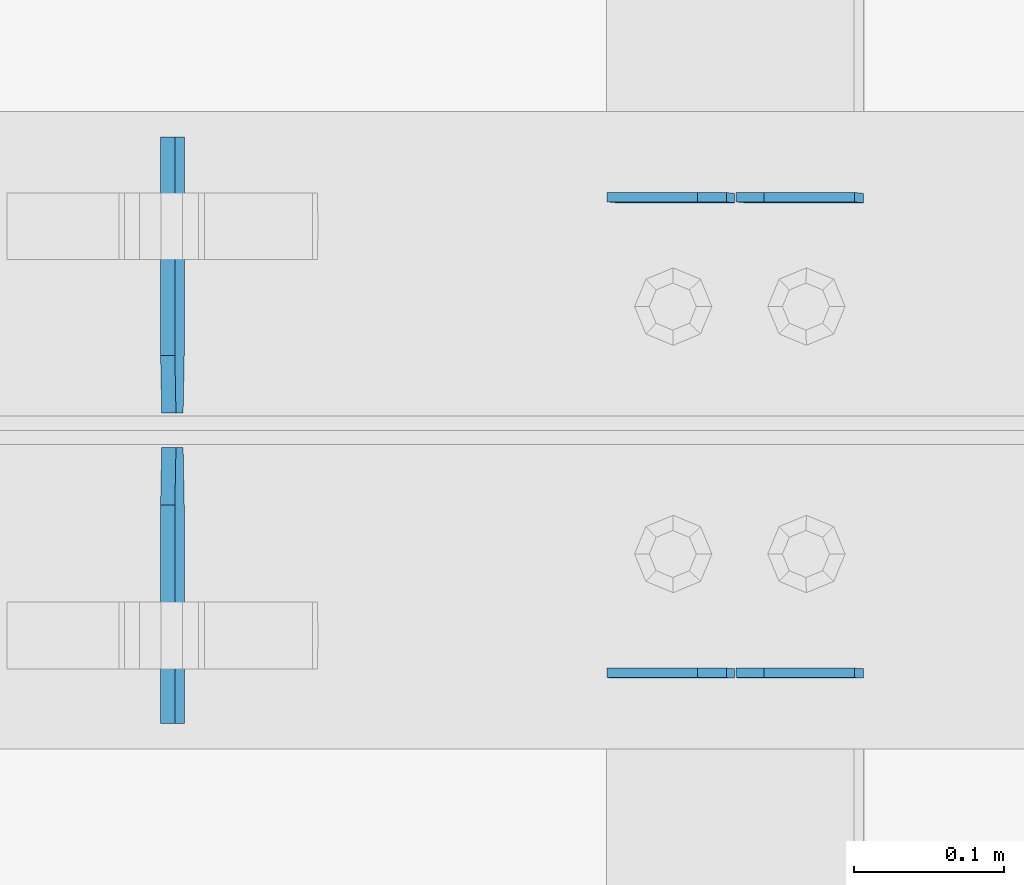
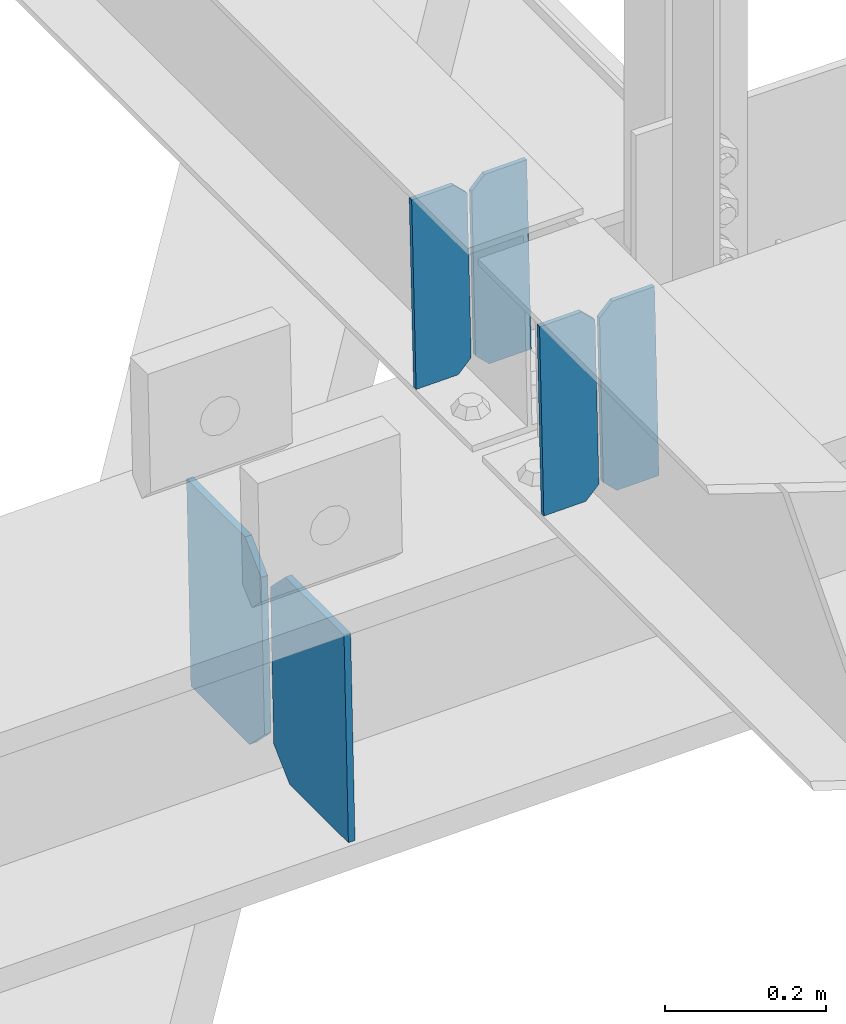
# One storey, part 3444 of 3843: 6 plates, 3 elements without a shape of their own.
"""IFC2X3 building model written with IfcOpenShell, lengths in millimetres."""

from ifc_helpers import new_model, si_unit, frame, origin_with_axes, place, context, subcontext, project, spatial, faceted_brep, material, type_object, element, aggregate, save


model = new_model("IFC2X3")

# Units and contexts
model_context = context("Model", 3, precision=1e-05, world=origin_with_axes())
body_context = subcontext(model_context, "Body", "Model", "MODEL_VIEW")
ifc_project = project(units=[si_unit("LENGTHUNIT", "METRE", prefix="MILLI"), si_unit("AREAUNIT", "SQUARE_METRE"), si_unit("VOLUMEUNIT", "CUBIC_METRE"), si_unit("MASSUNIT", "GRAM", prefix="KILO"), si_unit("TIMEUNIT", "SECOND"), si_unit("PLANEANGLEUNIT", "RADIAN"), si_unit("SOLIDANGLEUNIT", "STERADIAN"), si_unit("THERMODYNAMICTEMPERATUREUNIT", "DEGREE_CELSIUS"), si_unit("LUMINOUSINTENSITYUNIT", "LUMEN")], contexts=[model_context])

# Site, building, storey
site_placement = place(None, origin_with_axes())
site = spatial("IfcSite", under=ifc_project, at=site_placement, CompositionType="ELEMENT")
building_placement = place(site_placement, origin_with_axes())
building = spatial("IfcBuilding", under=site, at=building_placement, Name="Undefined", CompositionType="ELEMENT")
storey_placement = place(building_placement, origin_with_axes())
storey = spatial("IfcBuildingStorey", under=building, at=storey_placement, Name="Undefined", CompositionType="ELEMENT", Elevation=0.0)

# Assembly, plates
assembly_1_placement = place(storey_placement, origin_with_axes())
assembly_1 = element("IfcElementAssembly", 1, at=assembly_1_placement, inside=storey, Name="BEAM", AssemblyPlace="NOTDEFINED", PredefinedType="RIGID_FRAME")
ifc_material = material(Name="STEEL/A572-50")
plate_type_1 = type_object("IfcPlateType", PredefinedType="NOTDEFINED")
plate_1_placement = place(assembly_1_placement, frame((72027.796658837, 67426.8396238635, 46276.0659717988), z_axis=(-0.0211520979537891, 0.00212767700070982, 0.999774005334573), x_axis=(-0.999776269356297, -4.57939999836346e-05, -0.021152048007558)))
plate_1 = element("IfcPlate", 2, at=plate_1_placement, type_object=plate_type_1, material=ifc_material, Name="PLATE", context=body_context, shape_type="Brep", body=[
    faceted_brep([(0.0, -3.17499999999927, 0.0), (6.83940015733242e-10, -3.17499999996653, 288.924999998613), (6.54836185276508e-10, 3.17500000001746, 288.924999998591), (0.0, 3.17499999999927, 0.0), (60.3250007643655, -3.17500000017753, 288.924999998606), (60.3250007643219, 3.17499999979918, 288.924999998584), (79.3750000013097, -3.17500000025029, 269.875000761494), (79.375000001266, 3.17499999972642, 269.875000761487), (79.375000000713, -3.17500000026484, 19.0499992370605), (79.3750000006985, 3.17499999971187, 19.0499992370533), (60.325000763667, -3.17500000020664, -1.45519152283669e-11), (60.3250007636234, 3.17499999977736, -3.63797880709171e-11)], [[[0, 1, 2, 3]], [[1, 4, 5, 2]], [[4, 6, 7, 5]], [[6, 8, 9, 7]], [[8, 10, 11, 9]], [[10, 0, 3, 11]], [[5, 7, 9, 11, 3, 2]], [[10, 8, 6, 4, 1, 0]]]),
])
plate_2_placement = place(assembly_1_placement, frame((71942.0908381468, 67426.8357630742, 46274.2527123076), z_axis=(-0.0211520979537891, 0.00212767700070982, 0.999774005334573), x_axis=(-0.999776269356297, -4.57939999836346e-05, -0.021152048007558)))
plate_2 = element("IfcPlate", 3, at=plate_2_placement, type_object=plate_type_1, material=ifc_material, Name="PLATE", context=body_context, shape_type="Brep", body=[
    faceted_brep([(4.36557456851006e-11, -3.17499999998836, 19.0499992370969), (6.11180439591408e-10, -3.17499999996653, 269.875000761516), (5.96628524363041e-10, 3.17500000001746, 269.875000761502), (1.45519152283669e-11, 3.17499999998836, 19.0499992370824), (19.0499992376572, -3.17500000003201, 288.924999998606), (19.0499992376281, 3.1749999999447, 288.924999998584), (79.3750000013242, -3.17500000025029, 288.924999998591), (79.3750000013097, 3.1749999997337, 288.92499999857), (79.3750000006548, -3.17500000026484, -2.18278728425503e-11), (79.3750000006403, 3.17499999969732, -2.91038304567337e-11), (19.0499992370023, -3.17500000005384, 0.0), (19.0499992369587, 3.17499999992287, -1.45519152283669e-11)], [[[0, 1, 2, 3]], [[1, 4, 5, 2]], [[4, 6, 7, 5]], [[6, 8, 9, 7]], [[8, 10, 11, 9]], [[10, 0, 3, 11]], [[5, 7, 9, 11, 3, 2]], [[10, 8, 6, 4, 1, 0]]]),
])
aggregate(assembly_1, [plate_1, plate_2])

assembly_2_placement = place(storey_placement, origin_with_axes())
assembly_2 = element("IfcElementAssembly", 4, at=assembly_2_placement, inside=storey, Name="BEAM", AssemblyPlace="NOTDEFINED", PredefinedType="RIGID_FRAME")
plate_3_placement = place(assembly_2_placement, frame((72027.7966585924, 67109.8249895902, 46276.4772276004), z_axis=(-0.0211520976735046, 0.000503028999904926, 0.999776142806896), x_axis=(-0.999776269357269, -1.03370000525781e-05, -0.0211520950075214)))
plate_3 = element("IfcPlate", 5, at=plate_3_placement, type_object=plate_type_1, material=ifc_material, Name="PLATE", context=body_context, shape_type="Brep", body=[
    faceted_brep([(0.0, -3.17499999999927, 0.0), (6.83940015733242e-10, -3.17499999996653, 288.924999998613), (6.54836185276508e-10, 3.17500000001746, 288.924999998591), (0.0, 3.17499999999927, 0.0), (60.3250007643655, -3.17500000017753, 288.924999998606), (60.3250007643219, 3.17499999979918, 288.924999998584), (79.3750000013097, -3.17500000025029, 269.875000761494), (79.375000001266, 3.17499999972642, 269.875000761487), (79.375000000713, -3.17500000026484, 19.0499992370605), (79.3750000006985, 3.17499999971187, 19.0499992370533), (60.325000763667, -3.17500000020664, -1.45519152283669e-11), (60.3250007636234, 3.17499999977736, -3.63797880709171e-11)], [[[0, 1, 2, 3]], [[1, 4, 5, 2]], [[4, 6, 7, 5]], [[6, 8, 9, 7]], [[8, 10, 11, 9]], [[10, 0, 3, 11]], [[5, 7, 9, 11, 3, 2]], [[10, 8, 6, 4, 1, 0]]]),
])
plate_4_placement = place(assembly_2_placement, frame((71942.0908379013, 67109.8240791477, 46274.6639642276), z_axis=(-0.0211520976735046, 0.000503028999904926, 0.999776142806896), x_axis=(-0.999776269357269, -1.03370000525781e-05, -0.0211520950075214)))
plate_4 = element("IfcPlate", 6, at=plate_4_placement, type_object=plate_type_1, material=ifc_material, Name="PLATE", context=body_context, shape_type="Brep", body=[
    faceted_brep([(4.36557456851006e-11, -3.17499999998836, 19.0499992370969), (6.11180439591408e-10, -3.17499999996653, 269.875000761516), (5.96628524363041e-10, 3.17500000001746, 269.875000761502), (1.45519152283669e-11, 3.17499999998836, 19.0499992370824), (19.0499992376572, -3.17500000003201, 288.924999998606), (19.0499992376281, 3.1749999999447, 288.924999998584), (79.3750000013242, -3.17500000025029, 288.924999998591), (79.3750000013097, 3.1749999997337, 288.92499999857), (79.3750000006548, -3.17500000026484, -2.18278728425503e-11), (79.3750000006403, 3.17499999969732, -2.91038304567337e-11), (19.0499992370023, -3.17500000005384, 0.0), (19.0499992369587, 3.17499999992287, -1.45519152283669e-11)], [[[0, 1, 2, 3]], [[1, 4, 5, 2]], [[4, 6, 7, 5]], [[6, 8, 9, 7]], [[8, 10, 11, 9]], [[10, 0, 3, 11]], [[5, 7, 9, 11, 3, 2]], [[10, 8, 6, 4, 1, 0]]]),
])
aggregate(assembly_2, [plate_3, plate_4])

assembly_3_placement = place(storey_placement, origin_with_axes())
assembly_3 = element("IfcElementAssembly", 7, at=assembly_3_placement, inside=storey, Name="BEAM", AssemblyPlace="NOTDEFINED", PredefinedType="RIGID_FRAME")
plate_type_2 = type_object("IfcPlateType", PredefinedType="NOTDEFINED")
plate_5_placement = place(assembly_3_placement, frame((71569.8259376328, 67076.3375, 45900.4440101308), z_axis=(-0.019828109994094, 0.0, 0.999803403701979), x_axis=(0.0, 1.0, 0.0)))
plate_5 = element("IfcPlate", 8, at=plate_5_placement, type_object=plate_type_2, material=ifc_material, Name="PL", context=body_context, shape_type="Brep", body=[
    faceted_brep([(0.0, -4.76249999999709, 0.0), (0.0, -4.76249999986612, 316.893560966142), (0.0, 4.7625000000844, 316.893560966142), (0.0, 4.76249999999709, 0.0), (145.746763610834, -4.76249999986612, 316.893560966142), (145.746763610834, 4.7625000000844, 316.893560966142), (184.149999999994, -4.76249999989523, 278.490324577106), (184.149999999994, 4.76250000006985, 278.490324577098), (184.149999999994, -4.76249999999709, 38.4032363890365), (184.149999999994, 4.76249999998254, 38.4032363890365), (145.746763610834, -4.76250000001164, 7.27595761418343e-12), (145.746763610834, 4.76249999995343, 0.0)], [[[0, 1, 2, 3]], [[1, 4, 5, 2]], [[4, 6, 7, 5]], [[6, 8, 9, 7]], [[8, 10, 11, 9]], [[10, 0, 3, 11]], [[5, 7, 9, 11, 3, 2]], [[10, 8, 6, 4, 1, 0]]]),
])
plate_6_placement = place(assembly_3_placement, frame((71569.8259376328, 67283.3125, 45900.4440101308), z_axis=(-0.019828109994094, 0.0, 0.999803403701979), x_axis=(0.0, 1.0, 0.0)))
plate_6 = element("IfcPlate", 9, at=plate_6_placement, type_object=plate_type_2, material=ifc_material, Name="PL", context=body_context, shape_type="Brep", body=[
    faceted_brep([(0.0, -4.76249999999709, 38.4032363890365), (0.0, -4.76249999989523, 278.490324577106), (0.0, 4.76250000006985, 278.490324577098), (0.0, 4.76249999998254, 38.4032363890365), (38.4032363891602, -4.76249999986612, 316.893560966142), (38.4032363891602, 4.7625000000844, 316.893560966142), (184.149999999994, -4.76249999986612, 316.893560966142), (184.149999999994, 4.7625000000844, 316.893560966142), (184.150000000009, -4.76249999999709, 0.0), (184.150000000009, 4.76249999999709, 0.0), (38.4032363891602, -4.76250000001164, 7.27595761418343e-12), (38.4032363891602, 4.76249999995343, 0.0)], [[[0, 1, 2, 3]], [[1, 4, 5, 2]], [[4, 6, 7, 5]], [[6, 8, 9, 7]], [[8, 10, 11, 9]], [[10, 0, 3, 11]], [[5, 7, 9, 11, 3, 2]], [[10, 8, 6, 4, 1, 0]]]),
])
aggregate(assembly_3, [plate_5, plate_6])

save(model, "model.ifc")
